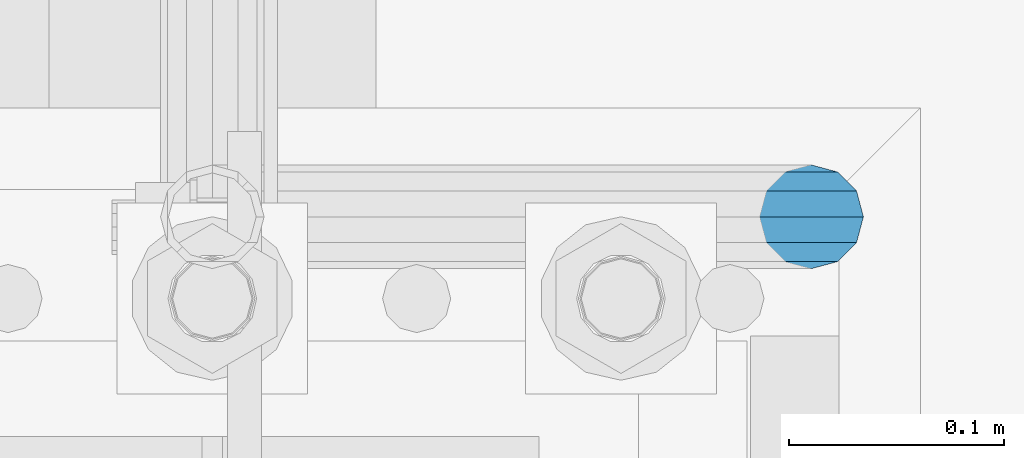
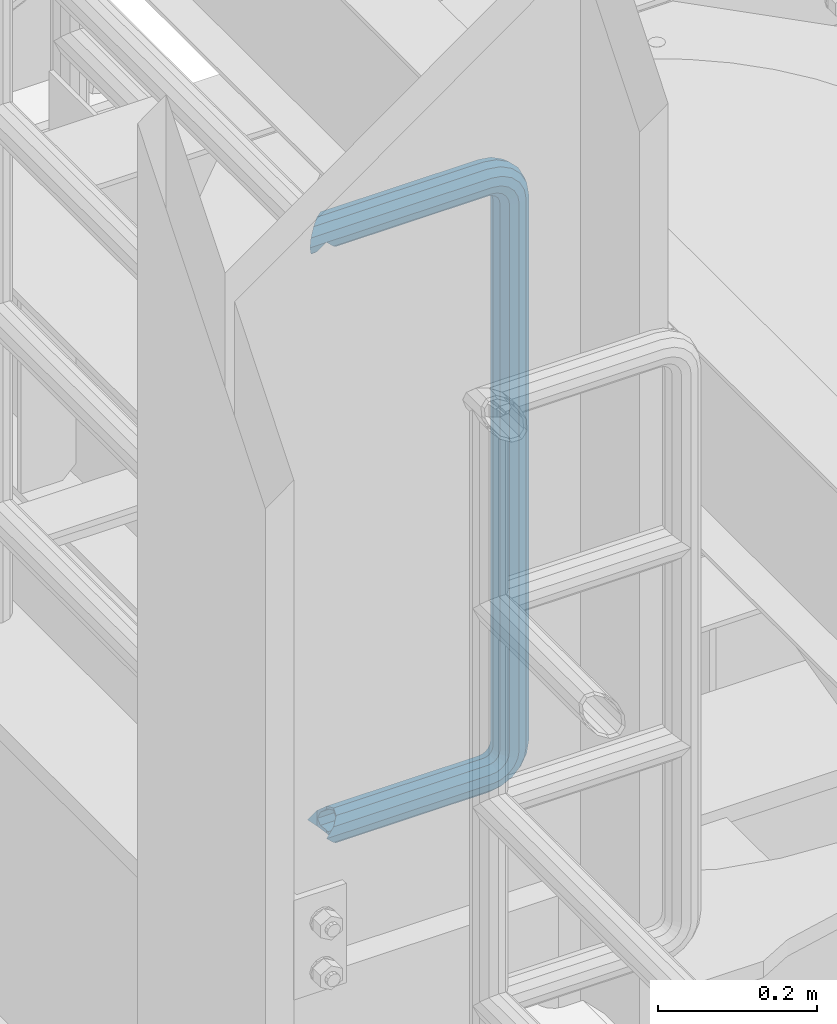
# One storey, part 956 of 1876: 1 beam, 1 element without a shape of its own.
"""IFC2X3 building model written with IfcOpenShell, lengths in millimetres."""

from ifc_helpers import new_model, si_unit, frame, origin_with_axes, place, context, subcontext, project, spatial, faceted_brep, material, type_object, element, aggregate, save


model = new_model("IFC2X3")

# Units and contexts
model_context = context("Model", 3, precision=1e-05, world=origin_with_axes())
body_context = subcontext(model_context, "Body", "Model", "MODEL_VIEW")
ifc_project = project(units=[si_unit("LENGTHUNIT", "METRE", prefix="MILLI"), si_unit("AREAUNIT", "SQUARE_METRE"), si_unit("VOLUMEUNIT", "CUBIC_METRE"), si_unit("MASSUNIT", "GRAM", prefix="KILO"), si_unit("TIMEUNIT", "SECOND"), si_unit("PLANEANGLEUNIT", "RADIAN"), si_unit("SOLIDANGLEUNIT", "STERADIAN"), si_unit("THERMODYNAMICTEMPERATUREUNIT", "DEGREE_CELSIUS"), si_unit("LUMINOUSINTENSITYUNIT", "LUMEN")], contexts=[model_context])

# Site, building, storey
site_placement = place(None, origin_with_axes())
site = spatial("IfcSite", under=ifc_project, at=site_placement, CompositionType="ELEMENT")
building_placement = place(site_placement, origin_with_axes())
building = spatial("IfcBuilding", under=site, at=building_placement, Name="Undefined", CompositionType="ELEMENT")
storey_placement = place(building_placement, origin_with_axes())
storey = spatial("IfcBuildingStorey", under=building, at=storey_placement, Name="Undefined", CompositionType="ELEMENT", Elevation=0.0)

# Assembly, beam
assembly_placement = place(storey_placement, origin_with_axes())
assembly = element("IfcElementAssembly", 1, at=assembly_placement, inside=storey, Name="RAIL", AssemblyPlace="NOTDEFINED", PredefinedType="RIGID_FRAME")
ifc_material = material()
beam_type = type_object("IfcBeamType", Name="PIPE1-1/2SCH40", PredefinedType="NOTDEFINED")
beam_placement = place(assembly_placement, frame((-5.00222085975111e-12, -4356.1, 19059.525), z_axis=(0.0, 0.0, 1.0), x_axis=(1.0, 0.0, 0.0)))
beam = element("IfcBeam", 2, at=beam_placement, type_object=beam_type, material=ifc_material, Name="RAIL", ObjectType="PIPE1-1/2SCH40", context=body_context, shape_type="Brep", body=[
    faceted_brep([(16.4810964966631, 16.4810964966564, -11.4500249345219), (16.481099754581, 16.4810997545774, -16.4810932387409), (20.8971929933249, 12.0650000000005, -20.8971929933177), (20.8971929933249, 12.0650000000005, -15.8661214311796), (0.0, -24.1299999999992, 0.0), (12.0650000000014, -20.8971929933186, 0.0), (12.0650000000064, -20.8971929933177, -12.0649999999987), (-12.0650000000096, -20.8971929933177, -12.0649999999987), (-12.0649999999986, -20.8971929933186, 0.0), (-16.481093238739, -16.4810932387427, -16.4810997545756), (-16.4810964966554, -16.4810964966618, -11.4500249345183), (-15.2545715621367, -17.7076214311801, -10.2235000000001), (-12.5151929933171, -20.4470000000001, 0.0), (12.5151929933249, -20.4470000000001, 0.0), (20.8971929933249, -12.0650000000005, -15.8661214311796), (20.8971929933249, -12.0650000000005, -20.8971929933177), (15.2545715621445, -17.7076214311801, -10.2235000000001), (24.1300000000063, 0.0, -20.4470000000001), (24.1300000000063, 0.0, -24.130000000001), (21.3906214311868, -10.2235000000001, -17.7076214311819), (21.3906214311868, 10.2235000000001, -17.7076214311819), (1.20714750983051e-12, 24.1299999999974, -914.399963378906), (12.0650000000014, 20.8971929933159, -926.464963378905), (12.0650000000014, 20.8971929933177, -902.334963378908), (12.0650000000014, -20.8971929933195, -902.334963378908), (12.0650000000014, -20.8971929933195, -926.464963378905), (1.52133659548828e-12, -24.130000000001, -914.399963378906), (20.8971929933199, -12.0650000000023, -893.502770385589), (20.8971929933199, -12.0650000000005, -898.533841947723), (15.2545715621378, -17.7076214311819, -904.176463378906), (12.5151929933181, -20.4470000000019, -914.399963378906), (15.2545715621376, -17.7076214311819, -924.623463378906), (20.8971929933199, -12.0650000000005, -930.26608481009), (20.8971929933199, -12.0650000000023, -935.297156372224), (24.1300000000014, -1.81898940354586e-12, -934.846963378906), (24.1300000000014, -1.81898940354586e-12, -938.529963378907), (21.3906214311813, -10.2235000000019, -932.107584810088), (21.3906214311823, 10.2234999999982, -932.107584810088), (20.8971929933199, 12.0650000000005, -930.266084810086), (20.8971929933199, 12.0649999999987, -935.297156372224), (15.2545715621413, 17.7076214311783, -924.623463378906), (12.5151929933216, 20.4469999999983, -914.399963378906), (15.2545715621411, 17.7076214311783, -904.176463378906), (20.8971929933199, 12.0650000000005, -898.533841947727), (20.8971929933199, 12.0649999999987, -893.502770385589), (21.3906214311822, 10.2234999999982, -896.692341947724), (24.1300000000014, 0.0, -893.952963378906), (24.1300000000014, 0.0, -890.269963378905), (21.3906214311814, -10.2235000000019, -896.692341947724), (241.299995422363, -20.8971929933177, 12.0649999999987), (241.299995422363, -24.1299999999992, 0.0), (253.073542436527, -24.1299999999992, -1.86474665447167), (256.801832473661, -20.8971929933177, 9.60975021462946), (241.299995422363, -12.0650000000005, 20.8971929933177), (259.531130206197, -12.0650000000005, 18.0096649141014), (241.299995422363, 0.0, 24.130000000001), (260.530122510796, 0.0, 21.084247083727), (241.299995422363, 12.0650000000005, 20.8971929933177), (259.531130206197, 12.0650000000005, 18.0096649141014), (241.299995422363, 20.8971929933177, 12.0649999999987), (256.801832473661, 20.8971929933177, 9.60975021462946), (241.299995422363, 24.1299999999992, 0.0), (253.073542436527, 24.1299999999992, -1.86474665447167), (241.299995422363, 20.8971929933177, -12.0649999999987), (249.345252399393, 20.8971929933177, -13.3392435235728), (241.299995422363, 12.0650000000005, -20.8971929933177), (246.615954666858, 12.0650000000005, -21.7391582230448), (241.299995422363, 0.0, -24.130000000001), (245.616962362259, 0.0, -24.8137403926739), (241.299995422363, -12.0650000000005, -20.8971929933177), (246.615954666858, -12.0650000000005, -21.7391582230448), (241.299995422363, -20.8971929933177, -12.0649999999987), (249.345252399393, -20.8971929933177, -13.3392435235728), (267.334993896485, 20.8971929933177, -38.0999984741211), (279.399993896485, 24.1299999999992, -38.0999984741211), (279.399993896484, 24.1299999999992, -876.299964904785), (267.334993896484, 20.8971929933177, -876.299964904785), (291.464993896486, 20.8971929933177, -38.0999984741211), (291.464993896484, 20.8971929933177, -876.299964904785), (300.297186889804, 12.0650000000005, -38.0999984741211), (300.297186889803, 12.0650000000005, -876.299964904785), (303.529993896486, 0.0, -38.0999984741211), (303.529993896484, 0.0, -876.299964904785), (300.297186889804, -12.0650000000005, -38.0999984741211), (300.297186889803, -12.0650000000005, -876.299964904785), (291.464993896486, -20.8971929933177, -38.0999984741211), (291.464993896484, -20.8971929933177, -876.299964904785), (279.399993896484, -24.1299999999992, -38.0999984741211), (279.399993896484, -24.1299999999992, -876.299964904785), (267.334993896485, -20.8971929933177, -38.0999984741211), (267.334993896484, -20.8971929933177, -876.299964904785), (258.502800903167, -12.0650000000005, -38.0999984741211), (258.502800903166, -12.0650000000005, -876.299964904785), (255.269993896485, 0.0, -38.0999984741211), (255.269993896484, 0.0, -876.299964904785), (258.502800903167, 12.0650000000005, -38.0999984741211), (258.502800903166, 12.0650000000005, -876.299964904785), (257.660835673438, 12.0650000000005, -881.615924149282), (254.586253503809, 0.0, -880.616931844681), (257.660835673438, -12.0650000000005, -881.615924149282), (266.06075037291, -20.8971929933177, -884.345221881817), (277.535247242011, -24.130000000001, -888.073511918952), (289.009744111112, -20.8971929933195, -891.801801956084), (297.409658810584, -12.0650000000005, -894.531099688622), (300.484240980214, 0.0, -895.53009199322), (297.409658810584, 12.0650000000005, -894.531099688622), (289.009744111112, 20.8971929933177, -891.801801956084), (277.535247242011, 24.1299999999992, -888.073511918952), (266.06075037291, 20.8971929933177, -884.345221881817), (241.299995422364, -1.81898940354586e-12, -938.529963378911), (241.299995422364, -12.0650000000005, -935.297156372228), (241.299995422364, -20.8971929933195, -926.464963378909), (241.299995422363, -24.130000000001, -914.399963378906), (241.299995422363, -20.8971929933195, -902.334963378908), (241.299995422363, -12.0650000000005, -893.502770385589), (241.299995422363, 0.0, -890.269963378909), (241.299995422364, 20.8971929933177, -926.464963378909), (241.299995422364, 12.0649999999987, -935.297156372228), (241.299995422364, 24.1299999999992, -914.39996337891), (241.299995422363, 20.8971929933177, -902.334963378908), (241.299995422363, 12.0649999999987, -893.502770385589), (260.530122510801, 0.0, -935.484210462637), (259.531130206202, 12.0649999999987, -932.409628293008), (259.531130206201, -12.0650000000005, -932.409628293008), (256.801832473666, -20.8971929933195, -924.009713593536), (253.07354243653, -24.130000000001, -912.535216724435), (249.345252399395, -20.8971929933195, -901.060719855333), (246.615954666859, -12.0650000000005, -892.660805155861), (245.61696236226, 0.0, -889.586222986232), (246.615954666859, 12.0649999999987, -892.660805155861), (249.345252399395, 20.8971929933177, -901.060719855333), (253.07354243653, 24.1299999999992, -912.535216724435), (256.801832473666, 20.8971929933177, -924.009713593536), (275.977674493594, 12.0649999999987, -924.029695422345), (270.786241706733, 20.8971929933177, -916.884301193139), (277.877870775644, 0.0, -926.645091230272), (275.977674493608, -12.0650000000005, -924.029695422334), (270.786241706733, -20.8971929933195, -916.884301193139), (263.694612637823, -24.130000000001, -907.123511156005), (256.602983568912, -20.8971929933195, -897.362721118872), (251.411550782037, -12.0650000000005, -890.21732688968), (249.511354500001, 0.0, -887.601931081743), (251.411550782037, 12.0650000000005, -890.21732688968), (256.602983568912, 20.8971929933177, -897.362721118872), (263.694612637823, 24.1299999999992, -907.123511156005), (281.884331710718, 20.8971929933177, -905.786211189152), (272.123541673585, 24.1299999999992, -898.694582120243), (289.029725939912, 12.0650000000005, -910.977643976028), (291.645121747852, 0.0, -912.877840258065), (289.029725939912, -12.0650000000005, -910.977643976028), (281.884331710718, -20.8971929933195, -905.786211189152), (272.123541673585, -24.130000000001, -898.694582120243), (262.362751636451, -20.8971929933195, -891.602953051333), (255.217357407258, -12.0650000000005, -886.411520264461), (252.601961599318, 0.0, -884.511323982424), (255.217357407258, 12.0650000000005, -886.411520264461), (262.362751636451, 20.8971929933177, -891.602953051333), (266.060750372911, 20.8971929933177, -30.0547414970897), (257.660835673439, 12.0650000000005, -32.7840392296275), (277.535247242011, 24.1299999999992, -26.3264514599541), (289.009744111112, 20.8971929933177, -22.5981614228222), (297.409658810584, 12.0650000000005, -19.8688636902843), (300.484240980213, 0.0, -18.8698713856866), (297.409658810584, -12.0650000000005, -19.8688636902843), (289.009744111112, -20.8971929933177, -22.5981614228222), (277.535247242011, -24.1299999999992, -26.3264514599541), (266.060750372911, -20.8971929933177, -30.0547414970897), (257.660835673439, -12.0650000000005, -32.7840392296275), (254.58625350381, 0.0, -33.7830315342253), (255.217357407257, 12.0650000000005, -27.9884431144455), (252.601961599318, 0.0, -29.8886393964822), (262.362751636451, 20.8971929933177, -22.7970103275729), (272.123541673583, 24.1299999999992, -15.7053812586601), (281.884331710716, 20.8971929933177, -8.61375218975081), (289.029725939909, 12.0650000000005, -3.42231940287456), (291.645121747848, 0.0, -1.52212312084157), (289.029725939909, -12.0650000000005, -3.42231940287456), (281.884331710716, -20.8971929933177, -8.61375218975081), (272.123541673583, -24.1299999999992, -15.7053812586601), (262.362751636451, -20.8971929933177, -22.7970103275729), (255.217357407257, -12.0650000000005, -27.9884431144455), (249.511354500002, 0.0, -26.7980322971671), (251.411550782037, -12.0650000000005, -24.1826364892258), (251.411550782037, 12.0650000000005, -24.1826364892258), (256.602983568912, 20.8971929933177, -17.037242260034), (263.694612637822, 24.1299999999992, -7.27645222290084), (270.786241706732, 20.8971929933177, 2.48433781423228), (275.977674493607, 12.0650000000005, 9.62973204342416), (277.877870775642, 0.0, 12.2451278513654), (275.977674493607, -12.0650000000005, 9.62973204342416), (270.786241706732, -20.8971929933177, 2.48433781423228), (263.694612637822, -24.1299999999992, -7.27645222290084), (256.602983568912, -20.8971929933177, -17.037242260034), (20.8971929933232, 20.8971929933177, -12.0649999999987), (24.1300000000047, 24.1299999999992, 0.0), (20.8971929933232, 20.8971929933177, 12.0649999999987), (12.0650000000041, 12.0650000000005, 20.8971929933177), (-1.45519152283669e-11, 0.0, 24.130000000001), (-12.0649999999951, -12.0650000000005, 20.8971929933177), (-20.8971929933141, -20.8971929933177, 12.0649999999987), (-24.1299999999956, -24.1299999999992, 0.0), (-20.8971929933141, -20.8971929933177, -12.0649999999987), (-17.7076214311755, -17.7076214311801, -10.2235000000001), (-20.4469999999956, -20.4470000000001, 0.0), (-17.7076214311755, -17.7076214311801, 10.2235000000001), (241.299995422363, -17.7076214311801, 10.2235000000001), (241.299995422363, -20.4470000000001, 0.0), (241.299995422363, -17.7076214311801, -10.2235000000001), (241.299995422363, -10.2235000000001, -17.7076214311819), (241.299995422363, 0.0, -20.4470000000001), (241.299995422363, 0.0, 20.4470000000001), (241.299995422363, -10.2235000000001, 17.7076214311819), (-10.2234999999955, -10.2235000000001, 17.7076214311819), (-1.45519152283669e-11, 0.0, 20.4470000000001), (241.299995422363, 10.2235000000001, 17.7076214311819), (10.2235000000046, 10.2235000000001, 17.7076214311819), (241.299995422363, 17.7076214311801, 10.2235000000001), (17.7076214311846, 17.7076214311801, 10.2235000000001), (241.299995422363, 20.4470000000001, 0.0), (20.4470000000047, 20.4470000000001, 0.0), (241.299995422363, 17.7076214311801, -10.2235000000001), (17.7076214311846, 17.7076214311801, -10.2235000000001), (241.299995422363, 10.2235000000001, -17.7076214311819), (258.545498388721, -10.2235000000001, 14.9762020957387), (256.23277767852, -17.7076214311801, 7.85837963987069), (253.073542436527, -20.4470000000001, -1.86474665447167), (249.914307194535, -17.7076214311801, -11.5878729488177), (247.601586484334, -10.2235000000001, -18.7056954046857), (246.755071952542, 0.0, -21.31099924316), (247.601586484334, 10.2235000000001, -18.7056954046857), (249.914307194535, 17.7076214311801, -11.5878729488177), (253.073542436527, 20.4470000000001, -1.86474665447167), (256.23277767852, 17.7076214311801, 7.85837963987069), (258.545498388721, 10.2235000000001, 14.9762020957387), (259.392012920513, 0.0, 17.5815059342131), (275.713057691449, 0.0, 9.26551826108334), (274.10289136825, -10.2235000000001, 7.04931444488102), (274.10289136825, 10.2235000000001, 7.04931444488102), (269.703835164635, 17.7076214311801, 0.994533019089431), (263.694612637822, 20.4470000000001, -7.27645222290084), (257.685390111009, 17.7076214311801, -15.5474374648911), (253.286333907394, 10.2235000000001, -21.6022188906827), (251.676167584195, 0.0, -23.818422706885), (253.286333907394, -10.2235000000001, -21.6022188906827), (257.685390111009, -17.7076214311801, -15.5474374648911), (263.694612637822, -20.4470000000001, -7.27645222290084), (269.703835164635, -17.7076214311801, 0.994533019089431), (286.449308341364, -10.2235000000001, -5.29710252823133), (280.394526915574, -17.7076214311801, -9.69615873184739), (288.665512157566, 0.0, -3.68693620503473), (286.449308341364, 10.2235000000001, -5.29710252823133), (280.394526915574, 17.7076214311801, -9.69615873184739), (272.123541673583, 20.4470000000001, -15.7053812586601), (263.852556431592, 17.7076214311801, -21.7146037854764), (257.797775005802, 10.2235000000001, -26.1136599890888), (255.581571189601, 0.0, -27.723826312289), (257.797775005802, -10.2235000000001, -26.1136599890888), (263.852556431592, -17.7076214311801, -21.7146037854764), (272.123541673583, -20.4470000000001, -15.7053812586601), (287.258373536355, -17.7076214311801, -23.1672162179639), (277.535247242011, -20.4470000000001, -26.3264514599541), (294.376195992223, -10.2235000000001, -20.8544955077632), (296.981499830698, 0.0, -20.00798097597), (294.376195992223, 10.2235000000001, -20.8544955077632), (287.258373536355, 17.7076214311801, -23.1672162179639), (277.535247242011, 20.4470000000001, -26.3264514599541), (267.812120947668, 17.7076214311801, -29.485686701948), (260.6942984918, 10.2235000000001, -31.7984074121487), (258.088994653325, 0.0, -32.6449219439419), (260.6942984918, -10.2235000000001, -31.7984074121487), (267.812120947668, -17.7076214311801, -29.485686701948), (279.399993896484, -20.4470000000001, -38.0999984741211), (269.176493896485, -17.7076214311801, -38.0999984741211), (289.623493896486, -17.7076214311801, -38.0999984741211), (297.107615327666, -10.2235000000001, -38.0999984741211), (299.846993896486, 0.0, -38.0999984741211), (297.107615327666, 10.2235000000001, -38.0999984741211), (289.623493896486, 17.7076214311801, -38.0999984741211), (279.399993896485, 20.4470000000001, -38.0999984741211), (269.176493896485, 17.7076214311801, -38.0999984741211), (261.692372465305, 10.2235000000001, -38.0999984741211), (258.952993896485, 0.0, -38.0999984741211), (261.692372465305, -10.2235000000001, -38.0999984741211), (269.176493896484, -17.7076214311801, -876.299964904785), (261.692372465304, -10.2235000000001, -876.299964904785), (258.952993896484, 0.0, -876.299964904785), (261.692372465304, 10.2235000000001, -876.299964904785), (269.176493896484, 17.7076214311801, -876.299964904785), (279.399993896484, 20.4470000000001, -876.299964904785), (289.623493896484, 17.7076214311801, -876.299964904785), (297.107615327665, 10.2235000000001, -876.299964904785), (299.846993896484, 0.0, -876.299964904785), (297.107615327665, -10.2235000000001, -876.299964904785), (289.623493896484, -17.7076214311801, -876.299964904785), (279.399993896484, -20.4470000000001, -876.299964904785), (277.535247242011, -20.4470000000001, -888.073511918952), (267.812120947667, -17.7076214311801, -884.914276676958), (260.694298491799, -10.2235000000001, -882.601555966758), (258.088994653324, 0.0, -881.755041434964), (260.694298491799, 10.2235000000001, -882.601555966758), (267.812120947668, 17.7076214311801, -884.914276676958), (277.535247242011, 20.4470000000001, -888.073511918952), (287.258373536355, 17.7076214311801, -891.232747160942), (294.376195992223, 10.2235000000001, -893.545467871143), (296.981499830699, 0.0, -894.391982402936), (294.376195992223, -10.2235000000001, -893.545467871143), (287.258373536355, -17.7076214311801, -891.232747160942), (280.394526915577, -17.7076214311801, -904.703804647055), (272.123541673585, -20.4470000000001, -898.694582120243), (286.449308341367, -10.2235000000001, -909.102860850671), (288.665512157569, 0.0, -910.713027173868), (286.449308341367, 10.2235000000001, -909.102860850671), (280.394526915577, 17.7076214311801, -904.703804647055), (272.123541673585, 20.4470000000001, -898.694582120243), (263.852556431593, 17.7076214311801, -892.68535959343), (257.797775005802, 10.2235000000001, -888.286303389817), (255.581571189601, 0.0, -886.676137066617), (257.797775005802, -10.2235000000001, -888.286303389817), (263.852556431593, -17.7076214311801, -892.68535959343), (263.694612637823, -20.4470000000001, -907.123511156005), (257.685390111009, -17.7076214311801, -898.852525914015), (269.703835164636, -17.7076214311801, -915.394496397999), (274.102891368238, -10.2235000000001, -921.449277823798), (275.71305769145, 0.0, -923.66548163999), (274.102891368251, 10.2235000000001, -921.449277823787), (269.703835164636, 17.7076214311801, -915.394496397999), (263.694612637823, 20.4470000000001, -907.123511156005), (257.685390111009, 17.7076214311801, -898.852525914015), (253.286333907394, 10.2235000000001, -892.797744488227), (251.676167584195, 0.0, -890.581540672025), (253.286333907394, -10.2235000000001, -892.797744488227), (249.914307194537, -17.7076214311801, -902.812090430092), (247.601586484335, -10.2235000000001, -895.694267974224), (253.07354243653, -20.4470000000001, -912.535216724435), (256.232777678524, -17.7076214311819, -922.258343018777), (258.545498388725, -10.2235000000001, -929.376165474645), (259.392012920517, 0.0, -931.981469313119), (258.545498388725, 10.2235000000001, -929.376165474645), (256.232777678524, 17.7076214311801, -922.258343018777), (253.07354243653, 20.4470000000001, -912.535216724435), (249.914307194537, 17.7076214311801, -902.812090430092), (247.601586484335, 10.2235000000001, -895.694267974224), (246.755071952543, 0.0, -893.088964135746), (241.299995422363, -10.2235000000001, -896.692341947728), (241.299995422363, 0.0, -893.95296337891), (241.299995422363, -17.7076214311819, -904.17646337891), (241.299995422363, -20.4470000000001, -914.399963378906), (241.299995422364, -17.7076214311819, -924.62346337891), (241.299995422364, -10.2235000000001, -932.107584810088), (241.299995422364, -1.81898940354586e-12, -934.84696337891), (241.299995422364, 10.2234999999982, -932.107584810088), (241.299995422364, 17.7076214311801, -924.62346337891), (241.299995422364, 20.4470000000001, -914.39996337891), (241.299995422363, 17.7076214311801, -904.17646337891), (241.299995422363, 10.2235000000001, -896.692341947728)], [[[0, 1, 2, 3]], [[4, 5, 6]], [[7, 8, 4]], [[9, 10, 11, 12, 8, 7]], [[13, 5, 4, 8, 12]], [[14, 15, 6, 5, 13, 16]], [[17, 18, 15, 14, 19]], [[20, 3, 2, 18, 17]], [[21, 22, 23]], [[24, 25, 26]], [[27, 28, 29, 30, 31, 32, 33, 25, 24]], [[34, 35, 33, 32, 36]], [[37, 38, 39, 35, 34]], [[23, 22, 39, 38, 40, 41, 42, 43, 44]], [[44, 43, 45, 46, 47]], [[47, 46, 48, 28, 27]], [[49, 50, 51, 52]], [[53, 49, 52, 54]], [[55, 53, 54, 56]], [[57, 55, 56, 58]], [[59, 57, 58, 60]], [[61, 59, 60, 62]], [[63, 61, 62, 64]], [[65, 63, 64, 66]], [[67, 65, 66, 68]], [[69, 67, 68, 70]], [[71, 69, 70, 72]], [[73, 74, 75, 76]], [[74, 77, 78, 75]], [[77, 79, 80, 78]], [[79, 81, 82, 80]], [[81, 83, 84, 82]], [[83, 85, 86, 84]], [[85, 87, 88, 86]], [[87, 89, 90, 88]], [[89, 91, 92, 90]], [[91, 93, 94, 92]], [[93, 95, 96, 94]], [[94, 96, 97, 98]], [[92, 94, 98, 99]], [[90, 92, 99, 100]], [[88, 90, 100, 101]], [[86, 88, 101, 102]], [[84, 86, 102, 103]], [[82, 84, 103, 104]], [[80, 82, 104, 105]], [[78, 80, 105, 106]], [[75, 78, 106, 107]], [[76, 75, 107, 108]], [[109, 110, 33, 35]], [[110, 111, 25, 33]], [[111, 112, 26, 25]], [[112, 113, 24, 26]], [[113, 114, 27, 24]], [[114, 115, 47, 27]], [[116, 117, 39, 22]], [[118, 116, 22, 21]], [[119, 118, 21, 23]], [[120, 119, 23, 44]], [[115, 120, 44, 47]], [[117, 109, 35, 39]], [[121, 109, 117, 122]], [[123, 110, 109, 121]], [[124, 111, 110, 123]], [[125, 112, 111, 124]], [[126, 113, 112, 125]], [[127, 114, 113, 126]], [[128, 115, 114, 127]], [[129, 120, 115, 128]], [[130, 119, 120, 129]], [[131, 118, 119, 130]], [[132, 116, 118, 131]], [[122, 117, 116, 132]], [[133, 122, 132, 134]], [[135, 121, 122, 133]], [[136, 123, 121, 135]], [[137, 124, 123, 136]], [[138, 125, 124, 137]], [[139, 126, 125, 138]], [[140, 127, 126, 139]], [[141, 128, 127, 140]], [[142, 129, 128, 141]], [[143, 130, 129, 142]], [[144, 131, 130, 143]], [[134, 132, 131, 144]], [[145, 134, 144, 146]], [[147, 133, 134, 145]], [[148, 135, 133, 147]], [[149, 136, 135, 148]], [[150, 137, 136, 149]], [[151, 138, 137, 150]], [[152, 139, 138, 151]], [[153, 140, 139, 152]], [[154, 141, 140, 153]], [[155, 142, 141, 154]], [[156, 143, 142, 155]], [[146, 144, 143, 156]], [[107, 146, 156, 108]], [[106, 145, 146, 107]], [[105, 147, 145, 106]], [[104, 148, 147, 105]], [[103, 149, 148, 104]], [[102, 150, 149, 103]], [[101, 151, 150, 102]], [[100, 152, 151, 101]], [[99, 153, 152, 100]], [[98, 154, 153, 99]], [[97, 155, 154, 98]], [[108, 156, 155, 97]], [[96, 76, 108, 97]], [[95, 73, 76, 96]], [[157, 73, 95, 158]], [[159, 74, 73, 157]], [[160, 77, 74, 159]], [[161, 79, 77, 160]], [[162, 81, 79, 161]], [[163, 83, 81, 162]], [[164, 85, 83, 163]], [[165, 87, 85, 164]], [[166, 89, 87, 165]], [[167, 91, 89, 166]], [[168, 93, 91, 167]], [[158, 95, 93, 168]], [[169, 158, 168, 170]], [[171, 157, 158, 169]], [[172, 159, 157, 171]], [[173, 160, 159, 172]], [[174, 161, 160, 173]], [[175, 162, 161, 174]], [[176, 163, 162, 175]], [[177, 164, 163, 176]], [[178, 165, 164, 177]], [[179, 166, 165, 178]], [[180, 167, 166, 179]], [[170, 168, 167, 180]], [[181, 170, 180, 182]], [[183, 169, 170, 181]], [[184, 171, 169, 183]], [[185, 172, 171, 184]], [[186, 173, 172, 185]], [[187, 174, 173, 186]], [[188, 175, 174, 187]], [[189, 176, 175, 188]], [[190, 177, 176, 189]], [[191, 178, 177, 190]], [[192, 179, 178, 191]], [[182, 180, 179, 192]], [[70, 182, 192, 72]], [[68, 181, 182, 70]], [[66, 183, 181, 68]], [[64, 184, 183, 66]], [[62, 185, 184, 64]], [[60, 186, 185, 62]], [[58, 187, 186, 60]], [[56, 188, 187, 58]], [[54, 189, 188, 56]], [[52, 190, 189, 54]], [[51, 191, 190, 52]], [[72, 192, 191, 51]], [[50, 71, 72, 51]], [[71, 50, 4, 6]], [[69, 71, 6, 15]], [[67, 69, 15, 18]], [[65, 67, 18, 2]], [[193, 63, 65, 2, 1]], [[61, 63, 193, 194]], [[59, 61, 194, 195]], [[57, 59, 195, 196]], [[55, 57, 196, 197]], [[53, 55, 197, 198]], [[49, 53, 198, 199]], [[4, 50, 49, 199, 200]], [[200, 201, 7, 4]], [[201, 9, 7]], [[202, 11, 10]], [[202, 203, 12, 11]], [[203, 204, 205, 206, 13, 12]], [[206, 207, 16, 13]], [[16, 207, 208, 19, 14]], [[208, 209, 17, 19]], [[210, 211, 212, 213]], [[214, 210, 213, 215]], [[216, 214, 215, 217]], [[218, 216, 217, 219]], [[220, 218, 219, 221]], [[222, 220, 221, 0, 3, 20]], [[209, 222, 20, 17]], [[221, 219, 217, 215, 213, 212, 204, 203, 202, 10, 9, 201, 200, 199, 198, 197, 196, 195, 194, 193, 1, 0]], [[211, 205, 204, 212]], [[205, 211, 223, 224]], [[206, 205, 224, 225]], [[207, 206, 225, 226]], [[208, 207, 226, 227]], [[209, 208, 227, 228]], [[222, 209, 228, 229]], [[220, 222, 229, 230]], [[218, 220, 230, 231]], [[216, 218, 231, 232]], [[214, 216, 232, 233]], [[210, 214, 233, 234]], [[211, 210, 234, 223]], [[234, 235, 236, 223]], [[233, 237, 235, 234]], [[232, 238, 237, 233]], [[231, 239, 238, 232]], [[230, 240, 239, 231]], [[229, 241, 240, 230]], [[228, 242, 241, 229]], [[227, 243, 242, 228]], [[226, 244, 243, 227]], [[225, 245, 244, 226]], [[224, 246, 245, 225]], [[223, 236, 246, 224]], [[236, 247, 248, 246]], [[235, 249, 247, 236]], [[237, 250, 249, 235]], [[238, 251, 250, 237]], [[239, 252, 251, 238]], [[240, 253, 252, 239]], [[241, 254, 253, 240]], [[242, 255, 254, 241]], [[243, 256, 255, 242]], [[244, 257, 256, 243]], [[245, 258, 257, 244]], [[246, 248, 258, 245]], [[248, 259, 260, 258]], [[247, 261, 259, 248]], [[249, 262, 261, 247]], [[250, 263, 262, 249]], [[251, 264, 263, 250]], [[252, 265, 264, 251]], [[253, 266, 265, 252]], [[254, 267, 266, 253]], [[255, 268, 267, 254]], [[256, 269, 268, 255]], [[257, 270, 269, 256]], [[258, 260, 270, 257]], [[260, 271, 272, 270]], [[259, 273, 271, 260]], [[261, 274, 273, 259]], [[262, 275, 274, 261]], [[263, 276, 275, 262]], [[264, 277, 276, 263]], [[265, 278, 277, 264]], [[266, 279, 278, 265]], [[267, 280, 279, 266]], [[268, 281, 280, 267]], [[269, 282, 281, 268]], [[270, 272, 282, 269]], [[282, 272, 283, 284]], [[281, 282, 284, 285]], [[280, 281, 285, 286]], [[279, 280, 286, 287]], [[278, 279, 287, 288]], [[277, 278, 288, 289]], [[276, 277, 289, 290]], [[275, 276, 290, 291]], [[274, 275, 291, 292]], [[273, 274, 292, 293]], [[271, 273, 293, 294]], [[272, 271, 294, 283]], [[283, 294, 295, 296]], [[284, 283, 296, 297]], [[285, 284, 297, 298]], [[286, 285, 298, 299]], [[287, 286, 299, 300]], [[288, 287, 300, 301]], [[289, 288, 301, 302]], [[290, 289, 302, 303]], [[291, 290, 303, 304]], [[292, 291, 304, 305]], [[293, 292, 305, 306]], [[294, 293, 306, 295]], [[306, 307, 308, 295]], [[305, 309, 307, 306]], [[304, 310, 309, 305]], [[303, 311, 310, 304]], [[302, 312, 311, 303]], [[301, 313, 312, 302]], [[300, 314, 313, 301]], [[299, 315, 314, 300]], [[298, 316, 315, 299]], [[297, 317, 316, 298]], [[296, 318, 317, 297]], [[295, 308, 318, 296]], [[308, 319, 320, 318]], [[307, 321, 319, 308]], [[309, 322, 321, 307]], [[310, 323, 322, 309]], [[311, 324, 323, 310]], [[312, 325, 324, 311]], [[313, 326, 325, 312]], [[314, 327, 326, 313]], [[315, 328, 327, 314]], [[316, 329, 328, 315]], [[317, 330, 329, 316]], [[318, 320, 330, 317]], [[320, 331, 332, 330]], [[319, 333, 331, 320]], [[321, 334, 333, 319]], [[322, 335, 334, 321]], [[323, 336, 335, 322]], [[324, 337, 336, 323]], [[325, 338, 337, 324]], [[326, 339, 338, 325]], [[327, 340, 339, 326]], [[328, 341, 340, 327]], [[329, 342, 341, 328]], [[330, 332, 342, 329]], [[332, 343, 344, 342]], [[331, 345, 343, 332]], [[333, 346, 345, 331]], [[334, 347, 346, 333]], [[335, 348, 347, 334]], [[336, 349, 348, 335]], [[337, 350, 349, 336]], [[338, 351, 350, 337]], [[339, 352, 351, 338]], [[340, 353, 352, 339]], [[341, 354, 353, 340]], [[342, 344, 354, 341]], [[354, 344, 46, 45]], [[42, 353, 354, 45, 43]], [[352, 353, 42, 41]], [[351, 352, 41, 40]], [[350, 351, 40, 38, 37]], [[349, 350, 37, 34]], [[348, 349, 34, 36]], [[31, 347, 348, 36, 32]], [[346, 347, 31, 30]], [[345, 346, 30, 29]], [[343, 345, 29, 28, 48]], [[344, 343, 48, 46]]]),
])
aggregate(assembly, [beam])

save(model, "model.ifc")
